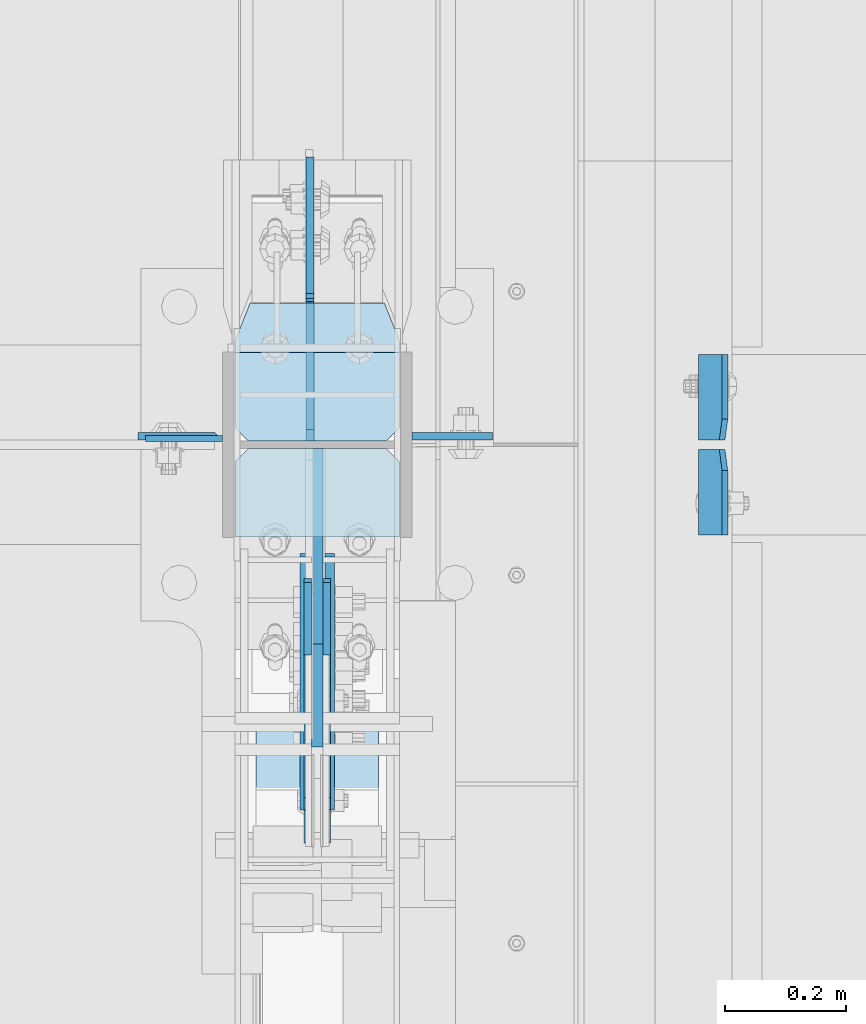
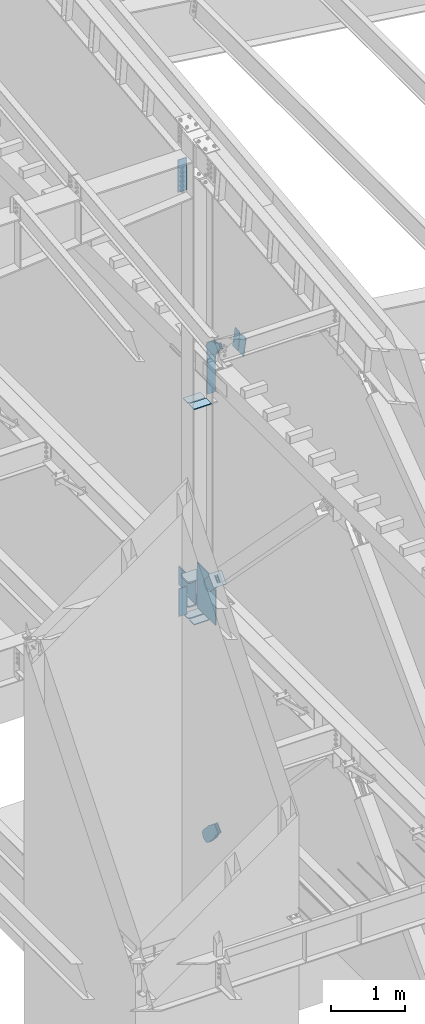
# One storey, part 1035 of 1179: 20 plates, 9 elements without a shape of their own.
"""IFC2X3 building model written with IfcOpenShell, lengths in millimetres."""

from ifc_helpers import new_model, si_unit, frame, origin_with_axes, place, context, subcontext, project, spatial, faceted_brep, material, type_object, element, aggregate, save


model = new_model("IFC2X3")

# Units and contexts
model_context = context("Model", 3, precision=1e-05, world=origin_with_axes())
body_context = subcontext(model_context, "Body", "Model", "MODEL_VIEW")
ifc_project = project(units=[si_unit("LENGTHUNIT", "METRE", prefix="MILLI"), si_unit("AREAUNIT", "SQUARE_METRE"), si_unit("VOLUMEUNIT", "CUBIC_METRE"), si_unit("MASSUNIT", "GRAM", prefix="KILO"), si_unit("TIMEUNIT", "SECOND"), si_unit("PLANEANGLEUNIT", "RADIAN"), si_unit("SOLIDANGLEUNIT", "STERADIAN"), si_unit("THERMODYNAMICTEMPERATUREUNIT", "DEGREE_CELSIUS"), si_unit("LUMINOUSINTENSITYUNIT", "LUMEN")], contexts=[model_context])

# Site, building, storey
site_placement = place(None, origin_with_axes())
site = spatial("IfcSite", under=ifc_project, at=site_placement, CompositionType="ELEMENT")
building_placement = place(site_placement, origin_with_axes())
building = spatial("IfcBuilding", under=site, at=building_placement, Name="Undefined", CompositionType="ELEMENT")
storey_placement = place(building_placement, origin_with_axes())
storey = spatial("IfcBuildingStorey", under=building, at=storey_placement, Name="Undefined", CompositionType="ELEMENT", Elevation=0.0)

# Assembly, plates
assembly_1_placement = place(storey_placement, origin_with_axes())
assembly_1 = element("IfcElementAssembly", 1, at=assembly_1_placement, inside=storey, Name="COLUMN", AssemblyPlace="NOTDEFINED", PredefinedType="RIGID_FRAME")
ifc_material_1 = material(Name="STEEL/A36")
plate_type_1 = type_object("IfcPlateType", PredefinedType="NOTDEFINED")
plate_1_placement = place(assembly_1_placement, frame((24150.6375, 19238.11875, 4051.3), z_axis=(-1.0, 0.0, 0.0), x_axis=(0.0, 0.0, -1.0)))
plate_1 = element("IfcPlate", 2, at=plate_1_placement, type_object=plate_type_1, material=ifc_material_1, Name="PLATE", context=body_context, shape_type="Brep", body=[
    faceted_brep([(0.0, -4.76249999999709, 0.0), (0.0, -4.76249999999709, 127.0), (0.0, 4.76249999999709, 127.0), (0.0, 4.76249999999709, 0.0), (457.200012207031, -4.76250000000073, 127.0), (457.200012207031, 4.76250000000073, 127.0), (457.200012207031, -4.76250000000073, 0.0), (457.200012207031, 4.76250000000073, 0.0)], [[[0, 1, 2, 3]], [[1, 4, 5, 2]], [[4, 6, 7, 5]], [[6, 0, 3, 7]], [[5, 7, 3, 2]], [[6, 4, 1, 0]]]),
])
plate_type_2 = type_object("IfcPlateType", PredefinedType="NOTDEFINED")
plate_2_placement = place(assembly_1_placement, frame((24010.9375000232, 19242.0874999987, 11089.4812512635), z_axis=(0.0, 0.0, -1.0), x_axis=(1.0, 0.0, 0.0)))
plate_2 = element("IfcPlate", 3, at=plate_2_placement, type_object=plate_type_2, material=ifc_material_1, Name="PLATE", context=body_context, shape_type="Brep", body=[
    faceted_brep([(127.000004873051, -6.34999999999854, 0.0), (139.699999999997, 6.35000000000036, 0.0), (139.700000000001, 6.35000000000036, 533.4), (127.0, -6.35000000000036, 533.4), (0.0, -6.34999999999854, 0.0), (0.0, -6.35000000000036, 533.4), (0.0, 6.35000000000036, 533.4), (0.0, 6.34999999999854, 0.0)], [[[0, 1, 2, 3]], [[4, 5, 6, 7]], [[6, 5, 3, 2]], [[4, 7, 1, 0]], [[2, 1, 7, 6]], [[5, 4, 0, 3]]]),
])

assembly_2_placement = place(storey_placement, origin_with_axes())
assembly_2 = element("IfcElementAssembly", 4, at=assembly_2_placement, inside=storey, Name="BEAM", AssemblyPlace="NOTDEFINED", PredefinedType="RIGID_FRAME")
plate_type_3 = type_object("IfcPlateType", PredefinedType="NOTDEFINED")
plate_3_placement = place(assembly_2_placement, frame((24982.9723149444, 19235.7375, 7924.64444967849), z_axis=(0.0, 1.0, 0.0), x_axis=(-0.133813222971046, 0.0, -0.991006569785539)))
plate_3 = element("IfcPlate", 5, at=plate_3_placement, type_object=plate_type_3, material=ifc_material_1, Name="PLATE", context=body_context, shape_type="Brep", body=[
    faceted_brep([(0.0, -4.76250000000073, 34.9249999999993), (0.0, -4.76250000001164, 141.287499999999), (-3.63797880709171e-12, 4.76249999998981, 141.287499999999), (0.0, 4.76250000000073, 34.9249999999993), (290.512500000297, -4.76249999966967, 141.287499999999), (290.512500000294, 4.76250000033906, 141.287499999999), (290.512500000297, -4.76249999966967, 0.0), (290.512500000294, 4.76250000033906, 0.0), (34.9249992370715, -4.76249999996799, 0.0), (34.9249992370678, 4.76250000003347, 0.0)], [[[0, 1, 2, 3]], [[1, 4, 5, 2]], [[4, 6, 7, 5]], [[6, 8, 9, 7]], [[8, 0, 3, 9]], [[5, 7, 9, 3, 2]], [[8, 6, 4, 1, 0]]]),
])
plate_4_placement = place(assembly_2_placement, frame((24982.9723149183, 19219.8625, 7924.6444497185), z_axis=(0.0, -1.0, 0.0), x_axis=(-0.133813222971046, 0.0, -0.991006569785539)))
plate_4 = element("IfcPlate", 6, at=plate_4_placement, type_object=plate_type_3, material=ifc_material_1, Name="PLATE", context=body_context, shape_type="Brep", body=[
    faceted_brep([(0.0, -4.76250000000073, 34.9249999999993), (0.0, -4.76250000001164, 141.287499999999), (-3.63797880709171e-12, 4.76249999998981, 141.287499999999), (0.0, 4.76250000000073, 34.9249999999993), (290.512500000297, -4.76249999966967, 141.287499999999), (290.512500000294, 4.76250000033906, 141.287499999999), (290.512500000297, -4.76249999966967, 0.0), (290.512500000294, 4.76250000033906, 0.0), (34.9249992370715, -4.76249999996799, 0.0), (34.9249992370678, 4.76250000003347, 0.0)], [[[0, 1, 2, 3]], [[1, 4, 5, 2]], [[4, 6, 7, 5]], [[6, 8, 9, 7]], [[8, 0, 3, 9]], [[5, 7, 9, 3, 2]], [[8, 6, 4, 1, 0]]]),
])
aggregate(assembly_2, [plate_3, plate_4])

# Assembly, plate
assembly_3_placement = place(storey_placement, origin_with_axes())
assembly_3 = element("IfcElementAssembly", 7, at=assembly_3_placement, inside=storey, AssemblyPlace="NOTDEFINED", PredefinedType="RIGID_FRAME")
plate_type_4 = type_object("IfcPlateType", PredefinedType="NOTDEFINED")
plate_5_placement = place(assembly_3_placement, frame((24291.925, 18622.7881405217, 8362.36594073939), z_axis=(0.0, -0.591857899923171, -0.806042322895352), x_axis=(0.0, 0.806042322895357, -0.591857899923163)))
plate_5 = element("IfcPlate", 8, at=plate_5_placement, type_object=plate_type_4, material=ifc_material_1, context=body_context, shape_type="Brep", body=[
    faceted_brep([(0.0, -6.34999999999854, 0.0), (-8.18545231595635e-11, -6.34999999999854, 91.5986124346418), (-8.18545231595635e-11, 6.34999999999854, 91.5986124346418), (0.0, 6.34999999999854, 0.0), (82.5500000001266, -6.34999999999854, 91.5986124347546), (82.5500000001266, 6.34999999999854, 91.5986124347546), (184.150000000493, -6.34999999999854, 136.286806217293), (184.150000000493, 6.34999999999854, 136.286806217293), (329.234985848627, -6.34999999999854, 136.286806217511), (329.234985848627, 6.34999999999854, 136.286806217511), (363.86305410257, -6.34999999999854, 129.398855183379), (363.86305410257, 6.34999999999854, 129.398855183379), (393.219312869078, -6.34999999999854, 109.783630186394), (393.219312869078, 6.34999999999854, 109.783630186394), (412.8345378661, -6.34999999999854, 80.4273714198789), (412.8345378661, 6.34999999999854, 80.4273714198789), (419.72248890029, -6.34999999999854, 45.7993092699908), (419.72248890029, 6.34999999999854, 45.7993092699908), (412.834537866132, -6.34999999999854, 11.171241015978), (412.834537866132, 6.34999999999854, 11.171241015978), (393.219312869132, -6.34999999999854, -18.1850177505985), (393.219312869132, 6.34999999999854, -18.1850177505985), (363.863054102636, -6.34999999999854, -37.8002427476786), (363.863054102636, 6.34999999999854, -37.8002427476786), (329.234988900062, -6.34999999999854, -44.6881937819198), (329.234988900062, 6.34999999999854, -44.6881937819198), (184.150000000598, -6.34999999999854, -44.6881937821345), (184.150000000598, 6.34999999999854, -44.6881937821345), (82.550000000203, -6.34999999999854, 1.2732925824821e-10), (82.550000000203, 6.34999999999854, 1.2732925824821e-10)], [[[0, 1, 2, 3]], [[1, 4, 5, 2]], [[4, 6, 7, 5]], [[6, 8, 9, 7]], [[8, 10, 11, 9]], [[10, 12, 13, 11]], [[12, 14, 15, 13]], [[14, 16, 17, 15]], [[16, 18, 19, 17]], [[18, 20, 21, 19]], [[20, 22, 23, 21]], [[22, 24, 25, 23]], [[24, 26, 27, 25]], [[26, 28, 29, 27]], [[28, 0, 3, 29]], [[5, 7, 9, 11, 13, 15, 17, 19, 21, 23, 25, 27, 29, 3, 2]], [[28, 26, 24, 22, 20, 18, 16, 14, 12, 10, 8, 6, 4, 1, 0]]]),
])
aggregate(assembly_3, [plate_5])

assembly_4_placement = place(storey_placement, origin_with_axes())
assembly_4 = element("IfcElementAssembly", 9, at=assembly_4_placement, inside=storey, AssemblyPlace="NOTDEFINED", PredefinedType="RIGID_FRAME")
plate_6_placement = place(assembly_4_placement, frame((24323.675, 18622.7881405217, 8362.36594073939), z_axis=(0.0, -0.591857899923171, -0.806042322895352), x_axis=(0.0, 0.806042322895357, -0.591857899923163)))
plate_6 = element("IfcPlate", 10, at=plate_6_placement, type_object=plate_type_4, material=ifc_material_1, context=body_context, shape_type="Brep", body=[
    faceted_brep([(0.0, -6.34999999999854, 0.0), (-8.18545231595635e-11, -6.34999999999854, 91.5986124346418), (-8.18545231595635e-11, 6.34999999999854, 91.5986124346418), (0.0, 6.34999999999854, 0.0), (82.5500000001266, -6.34999999999854, 91.5986124347546), (82.5500000001266, 6.34999999999854, 91.5986124347546), (184.150000000493, -6.34999999999854, 136.286806217293), (184.150000000493, 6.34999999999854, 136.286806217293), (329.234985848627, -6.34999999999854, 136.286806217511), (329.234985848627, 6.34999999999854, 136.286806217511), (363.86305410257, -6.34999999999854, 129.398855183379), (363.86305410257, 6.34999999999854, 129.398855183379), (393.219312869078, -6.34999999999854, 109.783630186394), (393.219312869078, 6.34999999999854, 109.783630186394), (412.8345378661, -6.34999999999854, 80.4273714198789), (412.8345378661, 6.34999999999854, 80.4273714198789), (419.72248890029, -6.34999999999854, 45.7993092699908), (419.72248890029, 6.34999999999854, 45.7993092699908), (412.834537866132, -6.34999999999854, 11.171241015978), (412.834537866132, 6.34999999999854, 11.171241015978), (393.219312869132, -6.34999999999854, -18.1850177505985), (393.219312869132, 6.34999999999854, -18.1850177505985), (363.863054102636, -6.34999999999854, -37.8002427476786), (363.863054102636, 6.34999999999854, -37.8002427476786), (329.234988900062, -6.34999999999854, -44.6881937819198), (329.234988900062, 6.34999999999854, -44.6881937819198), (184.150000000598, -6.34999999999854, -44.6881937821345), (184.150000000598, 6.34999999999854, -44.6881937821345), (82.550000000203, -6.34999999999854, 1.2732925824821e-10), (82.550000000203, 6.34999999999854, 1.2732925824821e-10)], [[[0, 1, 2, 3]], [[1, 4, 5, 2]], [[4, 6, 7, 5]], [[6, 8, 9, 7]], [[8, 10, 11, 9]], [[10, 12, 13, 11]], [[12, 14, 15, 13]], [[14, 16, 17, 15]], [[16, 18, 19, 17]], [[18, 20, 21, 19]], [[20, 22, 23, 21]], [[22, 24, 25, 23]], [[24, 26, 27, 25]], [[26, 28, 29, 27]], [[28, 0, 3, 29]], [[5, 7, 9, 11, 13, 15, 17, 19, 21, 23, 25, 27, 29, 3, 2]], [[28, 26, 24, 22, 20, 18, 16, 14, 12, 10, 8, 6, 4, 1, 0]]]),
])
aggregate(assembly_4, [plate_6])

assembly_5_placement = place(storey_placement, origin_with_axes())
assembly_5 = element("IfcElementAssembly", 11, at=assembly_5_placement, inside=storey, Name="Plate", AssemblyPlace="NOTDEFINED", PredefinedType="RIGID_FRAME")
plate_type_5 = type_object("IfcPlateType", PredefinedType="NOTDEFINED")
plate_7_placement = place(assembly_5_placement, frame((24206.2, 18613.4934226276, 4376.50104382377), z_axis=(0.0, 0.71564233903776, 0.698466923036849), x_axis=(1.0, 0.0, 0.0)))
plate_7 = element("IfcPlate", 12, at=plate_7_placement, type_object=plate_type_5, material=ifc_material_1, Name="Plate", context=body_context, shape_type="Brep", body=[
    faceted_brep([(0.0, -3.17500000000109, 0.0), (0.0, -3.17500000000291, 203.200000000368), (0.0, 3.17499999998836, 203.200000000361), (0.0, 3.17500000000109, 7.27595761418343e-12), (203.199999999997, -3.17500000000291, 203.200000000368), (203.199999999997, 3.17499999998836, 203.200000000361), (203.199999999997, -3.17499999999927, 3.63797880709171e-12), (203.199999999997, 3.17499999999382, -3.63797880709171e-12)], [[[0, 1, 2, 3]], [[1, 4, 5, 2]], [[4, 6, 7, 5]], [[6, 0, 3, 7]], [[5, 7, 3, 2]], [[6, 4, 1, 0]]]),
])
aggregate(assembly_5, [plate_7])

# Plate
ifc_material_2 = material(Name="STEEL/A572-GR.50")
plate_type_6 = type_object("IfcPlateType", PredefinedType="NOTDEFINED")
plate_8_placement = place(assembly_1_placement, frame((24444.325, 19462.75, 3694.1125), z_axis=(-1.0, 0.0, 0.0), x_axis=(0.0, -1.0, 0.0)))
plate_8 = element("IfcPlate", 13, at=plate_8_placement, type_object=plate_type_6, material=ifc_material_2, Name="PLATE", context=body_context, shape_type="Brep", body=[
    faceted_brep([(0.0, -11.1125000000002, 247.650000381473), (63.5, -11.1125000000002, 273.050000000003), (63.5, 11.1125000000002, 273.050000000003), (0.0, 11.1125000000002, 247.650000381473), (63.5, -11.1125000000002, 0.0), (0.0, -11.1125000000002, 25.3999996185303), (0.0, 11.1125000000002, 25.3999996185303), (63.5, 11.1125000000002, 0.0), (206.374999618529, -11.1125000000002, 0.0), (206.374999618529, 11.1125000000002, 0.0), (228.599999999999, -11.1125000000002, 22.2250003814697), (228.599999999999, 11.1125000000002, 22.2250003814697), (228.599999999999, -11.1125000000002, 250.824999618533), (228.599999999999, 11.1125000000002, 250.824999618533), (206.374999618529, -11.1125000000002, 273.050000000003), (206.374999618529, 11.1125000000002, 273.050000000003)], [[[0, 1, 2, 3]], [[4, 5, 6, 7]], [[8, 4, 7, 9]], [[10, 8, 9, 11]], [[12, 10, 11, 13]], [[14, 12, 13, 15]], [[4, 8, 10, 12, 14, 1, 0, 5]], [[5, 0, 3, 6]], [[2, 15, 13, 11, 9, 7, 6, 3]], [[1, 14, 15, 2]]]),
])

plate_9_placement = place(assembly_1_placement, frame((24444.325, 19462.75, 4090.9875), z_axis=(-1.0, 0.0, 0.0), x_axis=(0.0, -1.0, 0.0)))
plate_9 = element("IfcPlate", 14, at=plate_9_placement, type_object=plate_type_6, material=ifc_material_2, Name="PLATE", context=body_context, shape_type="Brep", body=[
    faceted_brep([(0.0, -11.1125000000002, 247.650000381473), (63.5, -11.1125000000002, 273.050000000003), (63.5, 11.1125000000002, 273.050000000003), (0.0, 11.1125000000002, 247.650000381473), (63.5, -11.1125000000002, 0.0), (0.0, -11.1125000000002, 25.3999996185303), (0.0, 11.1125000000002, 25.3999996185303), (63.5, 11.1125000000002, 0.0), (206.374999618529, -11.1125000000002, 0.0), (206.374999618529, 11.1125000000002, 0.0), (228.599999999999, -11.1125000000002, 22.2250003814697), (228.599999999999, 11.1125000000002, 22.2250003814697), (228.599999999999, -11.1125000000002, 250.824999618533), (228.599999999999, 11.1125000000002, 250.824999618533), (206.374999618529, -11.1125000000002, 273.050000000003), (206.374999618529, 11.1125000000002, 273.050000000003)], [[[0, 1, 2, 3]], [[4, 5, 6, 7]], [[8, 4, 7, 9]], [[10, 8, 9, 11]], [[12, 10, 11, 13]], [[14, 12, 13, 15]], [[4, 8, 10, 12, 14, 1, 0, 5]], [[5, 0, 3, 6]], [[2, 15, 13, 11, 9, 7, 6, 3]], [[1, 14, 15, 2]]]),
])

plate_type_7 = type_object("IfcPlateType", PredefinedType="NOTDEFINED")
plate_10_placement = place(assembly_1_placement, frame((24444.325, 19221.45, 7039.6831388093), z_axis=(-1.0, 0.0, 0.0), x_axis=(0.0, -1.0, 0.0)))
plate_10 = element("IfcPlate", 15, at=plate_10_placement, type_object=plate_type_7, material=ifc_material_1, Name="PLATE", context=body_context, shape_type="Brep", body=[
    faceted_brep([(0.0, -6.34999999999854, 22.2250003814697), (0.0, -6.35000000000036, 250.82499961853), (0.0, 6.35000000000036, 250.82499961853), (0.0, 6.34999999999854, 22.2250003814697), (22.2250003814697, -6.35000000000036, 273.05), (22.2250003814697, 6.35000000000036, 273.05), (146.050003051758, -6.35000000000036, 273.049987792969), (146.050003051758, 6.35000000000036, 273.049987792969), (146.050003051758, -6.35000000000036, 0.0), (146.050003051758, 6.35000000000036, 0.0), (22.2250003814697, -6.34999999999854, 0.0), (22.2250003814697, 6.34999999999854, 0.0)], [[[0, 1, 2, 3]], [[1, 4, 5, 2]], [[4, 6, 7, 5]], [[6, 8, 9, 7]], [[8, 10, 11, 9]], [[10, 0, 3, 11]], [[5, 7, 9, 11, 3, 2]], [[10, 8, 6, 4, 1, 0]]]),
])

plate_11_placement = place(assembly_1_placement, frame((24444.325, 19380.2, 7039.6831388093), z_axis=(-1.0, 0.0, 0.0), x_axis=(0.0, -1.0, 0.0)))
plate_11 = element("IfcPlate", 16, at=plate_11_placement, type_object=plate_type_7, material=ifc_material_1, Name="PLATE", context=body_context, shape_type="Brep", body=[
    faceted_brep([(0.0, -6.34999999999854, 0.0), (0.0, -6.34999999999991, 273.05), (0.0, 6.34999999999991, 273.05), (0.0, 6.34999999999854, 0.0), (123.824999618599, -6.34999999999991, 273.05), (123.824999618599, 6.34999999999991, 273.05), (146.050000000068, -6.34999999999991, 250.82499961853), (146.050000000068, 6.34999999999991, 250.82499961853), (146.050000000068, -6.34999999999991, 22.2250003814697), (146.050000000068, 6.34999999999991, 22.2250003814697), (123.824999618599, -6.34999999999991, 0.0), (123.824999618599, 6.34999999999991, 0.0)], [[[0, 1, 2, 3]], [[1, 4, 5, 2]], [[4, 6, 7, 5]], [[6, 8, 9, 7]], [[8, 10, 11, 9]], [[10, 0, 3, 11]], [[5, 7, 9, 11, 3, 2]], [[10, 8, 6, 4, 1, 0]]]),
])

plate_12_placement = place(assembly_1_placement, frame((24444.325, 19221.45, 3505.2), z_axis=(-1.0, 0.0, 0.0), x_axis=(0.0, -1.0, 0.0)))
plate_12 = element("IfcPlate", 17, at=plate_12_placement, type_object=plate_type_7, material=ifc_material_1, Name="PLATE", context=body_context, shape_type="Brep", body=[
    faceted_brep([(0.0, -6.34999999999854, 22.2250003814697), (0.0, -6.35000000000036, 250.82499961853), (0.0, 6.35000000000036, 250.82499961853), (0.0, 6.34999999999854, 22.2250003814697), (22.2250003814697, -6.35000000000036, 273.05), (22.2250003814697, 6.35000000000036, 273.05), (146.050003051758, -6.35000000000036, 273.049987792969), (146.050003051758, 6.35000000000036, 273.049987792969), (146.050003051758, -6.35000000000036, 0.0), (146.050003051758, 6.35000000000036, 0.0), (22.2250003814697, -6.34999999999854, 0.0), (22.2250003814697, 6.34999999999854, 0.0)], [[[0, 1, 2, 3]], [[1, 4, 5, 2]], [[4, 6, 7, 5]], [[6, 8, 9, 7]], [[8, 10, 11, 9]], [[10, 0, 3, 11]], [[5, 7, 9, 11, 3, 2]], [[10, 8, 6, 4, 1, 0]]]),
])

plate_13_placement = place(assembly_1_placement, frame((24444.325, 19380.2, 3505.2), z_axis=(-1.0, 0.0, 0.0), x_axis=(0.0, -1.0, 0.0)))
plate_13 = element("IfcPlate", 18, at=plate_13_placement, type_object=plate_type_7, material=ifc_material_1, Name="PLATE", context=body_context, shape_type="Brep", body=[
    faceted_brep([(0.0, -6.34999999999854, 0.0), (0.0, -6.34999999999991, 273.05), (0.0, 6.34999999999991, 273.05), (0.0, 6.34999999999854, 0.0), (123.824999618599, -6.34999999999991, 273.05), (123.824999618599, 6.34999999999991, 273.05), (146.050000000068, -6.34999999999991, 250.82499961853), (146.050000000068, 6.34999999999991, 250.82499961853), (146.050000000068, -6.34999999999991, 22.2250003814697), (146.050000000068, 6.34999999999991, 22.2250003814697), (123.824999618599, -6.34999999999991, 0.0), (123.824999618599, 6.34999999999991, 0.0)], [[[0, 1, 2, 3]], [[1, 4, 5, 2]], [[4, 6, 7, 5]], [[6, 8, 9, 7]], [[8, 10, 11, 9]], [[10, 0, 3, 11]], [[5, 7, 9, 11, 3, 2]], [[10, 8, 6, 4, 1, 0]]]),
])

plate_type_8 = type_object("IfcPlateType", PredefinedType="NOTDEFINED")
plate_14_placement = place(assembly_1_placement, frame((24464.9625, 19242.0875, 7936.73589790168), z_axis=(1.0, 0.0, 0.0), x_axis=(0.0, 0.0, -1.0)))
plate_14 = element("IfcPlate", 19, at=plate_14_placement, type_object=plate_type_8, material=ifc_material_1, Name="PLATE", context=body_context, shape_type="Brep", body=[
    faceted_brep([(0.0, -6.34999999999854, 0.0), (0.0, -6.34999999999854, 133.350000000002), (0.0, 6.34999999999854, 133.350000000002), (0.0, 6.34999999999854, 0.0), (850.900024414062, -6.34999999999854, 133.350006103516), (850.900024414062, 6.34999999999854, 133.350006103516), (850.900024414062, -6.34999999999854, 0.0), (850.900024414062, 6.34999999999854, 0.0)], [[[0, 1, 2, 3]], [[1, 4, 5, 2]], [[4, 6, 7, 5]], [[6, 0, 3, 7]], [[5, 7, 3, 2]], [[6, 4, 1, 0]]]),
])

# Assembly, plate
assembly_6_placement = place(storey_placement, origin_with_axes())
assembly_6 = element("IfcElementAssembly", 20, at=assembly_6_placement, inside=storey, AssemblyPlace="NOTDEFINED", PredefinedType="RIGID_FRAME")
plate_type_9 = type_object("IfcPlateType", PredefinedType="NOTDEFINED")
plate_15_placement = place(assembly_6_placement, frame((24291.925, 18724.1271949358, 4488.91617934531), z_axis=(0.0, -0.715642339037757, -0.698466923036852), x_axis=(0.0, 0.698466923036852, -0.715642339037758)))
plate_15 = element("IfcPlate", 21, at=plate_15_placement, type_object=plate_type_9, material=ifc_material_1, context=body_context, shape_type="Brep", body=[
    faceted_brep([(0.0, -6.34999999999854, 0.0), (-4.35647962149233e-10, -6.34999999999854, 112.184930806416), (-4.35647962149233e-10, 6.34999999999854, 112.184930806416), (0.0, 6.34999999999854, 0.0), (82.5499999996491, -6.34999999999854, 112.184930806461), (82.5499999996491, 6.34999999999854, 112.184930806461), (184.149999999618, -6.34999999999854, 149.75496540347), (184.149999999618, 6.34999999999854, 149.75496540347), (327.919242323534, -6.34999999999854, 149.754965403559), (327.919242323534, 6.34999999999854, 149.754965403559), (363.762328723451, -6.34999999999854, 142.625332233587), (363.762328723451, 6.34999999999854, 142.625332233587), (394.148630137406, -6.34999999999854, 122.321854743475), (394.148630137406, 6.34999999999854, 122.321854743475), (414.452107627645, -6.34999999999854, 91.9355533295929), (414.452107627645, 6.34999999999854, 91.9355533295929), (421.581740797776, -6.34999999999854, 56.0924638777396), (421.581740797776, 6.34999999999854, 56.0924638777396), (414.452107627878, -6.34999999999854, 20.2493774776722), (414.452107627878, 6.34999999999854, 20.2493774776722), (394.14863013775, -6.34999999999854, -10.1369239363994), (394.14863013775, 6.34999999999854, -10.1369239363994), (363.762328723789, -6.34999999999854, -30.4404014266784), (363.762328723789, 6.34999999999854, -30.4404014266784), (327.919240798041, -6.34999999999854, -37.570034596738), (327.919240798041, 6.34999999999854, -37.570034596738), (184.150000000338, -6.34999999999854, -37.5700345968289), (184.150000000338, 6.34999999999854, -37.5700345968289), (82.550000000203, -6.34999999999854, 1.2732925824821e-10), (82.550000000203, 6.34999999999854, 1.2732925824821e-10)], [[[0, 1, 2, 3]], [[1, 4, 5, 2]], [[4, 6, 7, 5]], [[6, 8, 9, 7]], [[8, 10, 11, 9]], [[10, 12, 13, 11]], [[12, 14, 15, 13]], [[14, 16, 17, 15]], [[16, 18, 19, 17]], [[18, 20, 21, 19]], [[20, 22, 23, 21]], [[22, 24, 25, 23]], [[24, 26, 27, 25]], [[26, 28, 29, 27]], [[28, 0, 3, 29]], [[5, 7, 9, 11, 13, 15, 17, 19, 21, 23, 25, 27, 29, 3, 2]], [[28, 26, 24, 22, 20, 18, 16, 14, 12, 10, 8, 6, 4, 1, 0]]]),
])
aggregate(assembly_6, [plate_15])

assembly_7_placement = place(storey_placement, origin_with_axes())
assembly_7 = element("IfcElementAssembly", 22, at=assembly_7_placement, inside=storey, AssemblyPlace="NOTDEFINED", PredefinedType="RIGID_FRAME")
plate_16_placement = place(assembly_7_placement, frame((24323.675, 18724.1271949358, 4488.91617934531), z_axis=(0.0, -0.715642339037757, -0.698466923036852), x_axis=(0.0, 0.698466923036852, -0.715642339037758)))
plate_16 = element("IfcPlate", 23, at=plate_16_placement, type_object=plate_type_9, material=ifc_material_1, context=body_context, shape_type="Brep", body=[
    faceted_brep([(0.0, -6.34999999999854, 0.0), (-4.35647962149233e-10, -6.34999999999854, 112.184930806416), (-4.35647962149233e-10, 6.34999999999854, 112.184930806416), (0.0, 6.34999999999854, 0.0), (82.5499999996491, -6.34999999999854, 112.184930806461), (82.5499999996491, 6.34999999999854, 112.184930806461), (184.149999999618, -6.34999999999854, 149.75496540347), (184.149999999618, 6.34999999999854, 149.75496540347), (327.919242323534, -6.34999999999854, 149.754965403559), (327.919242323534, 6.34999999999854, 149.754965403559), (363.762328723451, -6.34999999999854, 142.625332233587), (363.762328723451, 6.34999999999854, 142.625332233587), (394.148630137406, -6.34999999999854, 122.321854743475), (394.148630137406, 6.34999999999854, 122.321854743475), (414.452107627645, -6.34999999999854, 91.9355533295929), (414.452107627645, 6.34999999999854, 91.9355533295929), (421.581740797776, -6.34999999999854, 56.0924638777396), (421.581740797776, 6.34999999999854, 56.0924638777396), (414.452107627878, -6.34999999999854, 20.2493774776722), (414.452107627878, 6.34999999999854, 20.2493774776722), (394.14863013775, -6.34999999999854, -10.1369239363994), (394.14863013775, 6.34999999999854, -10.1369239363994), (363.762328723789, -6.34999999999854, -30.4404014266784), (363.762328723789, 6.34999999999854, -30.4404014266784), (327.919240798041, -6.34999999999854, -37.570034596738), (327.919240798041, 6.34999999999854, -37.570034596738), (184.150000000338, -6.34999999999854, -37.5700345968289), (184.150000000338, 6.34999999999854, -37.5700345968289), (82.550000000203, -6.34999999999854, 1.2732925824821e-10), (82.550000000203, 6.34999999999854, 1.2732925824821e-10)], [[[0, 1, 2, 3]], [[1, 4, 5, 2]], [[4, 6, 7, 5]], [[6, 8, 9, 7]], [[8, 10, 11, 9]], [[10, 12, 13, 11]], [[12, 14, 15, 13]], [[14, 16, 17, 15]], [[16, 18, 19, 17]], [[18, 20, 21, 19]], [[20, 22, 23, 21]], [[22, 24, 25, 23]], [[24, 26, 27, 25]], [[26, 28, 29, 27]], [[28, 0, 3, 29]], [[5, 7, 9, 11, 13, 15, 17, 19, 21, 23, 25, 27, 29, 3, 2]], [[28, 26, 24, 22, 20, 18, 16, 14, 12, 10, 8, 6, 4, 1, 0]]]),
])
aggregate(assembly_7, [plate_16])

# Plate
plate_type_10 = type_object("IfcPlateType", PredefinedType="NOTDEFINED")
plate_17_placement = place(assembly_1_placement, frame((24307.8, 19221.45, 3663.95), z_axis=(0.0, 0.0, 1.0), x_axis=(0.0, -1.0, 0.0)))
plate_17 = element("IfcPlate", 24, at=plate_17_placement, type_object=plate_type_10, material=ifc_material_2, Name="PLATE", context=body_context, shape_type="Brep", body=[
    faceted_brep([(0.0, -9.52499999999964, 0.0), (-3.63797880709171e-12, -9.52499999999998, 737.163128918689), (-3.63797880709171e-12, 9.52499999999998, 737.163128918689), (0.0, 9.52499999999964, 0.0), (323.636098339506, -9.52499999999998, 737.163128918689), (323.636098339506, 9.52499999999998, 737.163128918689), (494.048430322873, -9.52499999999998, 570.84069287054), (494.048430322873, 9.52499999999998, 570.84069287054), (494.048430322877, -9.52499999999998, 0.0), (494.048430322877, 9.52499999999998, 0.0)], [[[0, 1, 2, 3]], [[1, 4, 5, 2]], [[4, 6, 7, 5]], [[6, 8, 9, 7]], [[8, 0, 3, 9]], [[5, 7, 9, 3, 2]], [[8, 6, 4, 1, 0]]]),
])

# Assembly, plate
assembly_8_placement = place(storey_placement, origin_with_axes())
assembly_8 = element("IfcElementAssembly", 25, at=assembly_8_placement, inside=storey, AssemblyPlace="NOTDEFINED", PredefinedType="RIGID_FRAME")
plate_type_11 = type_object("IfcPlateType", PredefinedType="NOTDEFINED")
plate_18_placement = place(assembly_8_placement, frame((24287.1625, 18729.4707277224, 419.729946485768), z_axis=(0.0, -0.727605443744034, -0.685995858758672), x_axis=(0.0, 0.685995858758672, -0.727605443744034)))
plate_18 = element("IfcPlate", 26, at=plate_18_placement, type_object=plate_type_11, material=ifc_material_1, context=body_context, shape_type="Brep", body=[
    faceted_brep([(0.0, -7.9375, 0.0), (-8.00355337560177e-11, -7.9375, 146.904840309817), (-8.00355337560177e-11, 7.9375, 146.904840309817), (0.0, 7.9375, 0.0), (82.5499999998137, -7.9375, 146.90484031055), (82.5499999998137, 7.9375, 146.90484031055), (184.150000000214, -7.9375, 168.702420155054), (184.150000000214, 7.9375, 168.702420155054), (403.471138850085, -7.9375, 168.70242015493), (403.471138850085, 7.9375, 168.70242015493), (439.921735782846, -7.9375, 161.451945626626), (439.921735782846, 7.9375, 161.451945626626), (470.823059758064, -7.9375, 140.804341062974), (470.823059758064, 7.9375, 140.804341062974), (491.470664321725, -7.9375, 109.903017087783), (491.470664321725, 7.9375, 109.903017087783), (498.721138850011, -7.9375, 73.4524201549993), (498.721138850011, 7.9375, 73.4524201549993), (491.470664321694, -7.9375, 37.001823222241), (491.470664321694, 7.9375, 37.001823222241), (470.82305975797, -7.9375, 6.10049924700979), (470.82305975797, 7.9375, 6.10049924700979), (439.921735782676, -7.9375, -14.5471053166548), (439.921735782676, 7.9375, -14.5471053166548), (403.471138849898, -7.9375, -21.7975798449352), (403.471138849898, 7.9375, -21.7975798449352), (184.150000000169, -7.9375, -21.7975798448115), (184.150000000169, 7.9375, -21.7975798448115), (82.5500000000975, -7.9375, -6.91215973347425e-11), (82.5500000000975, 7.9375, -6.91215973347425e-11)], [[[0, 1, 2, 3]], [[1, 4, 5, 2]], [[4, 6, 7, 5]], [[6, 8, 9, 7]], [[8, 10, 11, 9]], [[10, 12, 13, 11]], [[12, 14, 15, 13]], [[14, 16, 17, 15]], [[16, 18, 19, 17]], [[18, 20, 21, 19]], [[20, 22, 23, 21]], [[22, 24, 25, 23]], [[24, 26, 27, 25]], [[26, 28, 29, 27]], [[28, 0, 3, 29]], [[5, 7, 9, 11, 13, 15, 17, 19, 21, 23, 25, 27, 29, 3, 2]], [[28, 26, 24, 22, 20, 18, 16, 14, 12, 10, 8, 6, 4, 1, 0]]]),
])
aggregate(assembly_8, [plate_18])

assembly_9_placement = place(storey_placement, origin_with_axes())
assembly_9 = element("IfcElementAssembly", 27, at=assembly_9_placement, inside=storey, AssemblyPlace="NOTDEFINED", PredefinedType="RIGID_FRAME")
plate_19_placement = place(assembly_9_placement, frame((24328.4375, 18729.4707277224, 419.729946485768), z_axis=(0.0, -0.727605443744034, -0.685995858758672), x_axis=(0.0, 0.685995858758672, -0.727605443744034)))
plate_19 = element("IfcPlate", 28, at=plate_19_placement, type_object=plate_type_11, material=ifc_material_1, context=body_context, shape_type="Brep", body=[
    faceted_brep([(0.0, -7.9375, 0.0), (-8.00355337560177e-11, -7.9375, 146.904840309817), (-8.00355337560177e-11, 7.9375, 146.904840309817), (0.0, 7.9375, 0.0), (82.5499999998137, -7.9375, 146.90484031055), (82.5499999998137, 7.9375, 146.90484031055), (184.150000000214, -7.9375, 168.702420155054), (184.150000000214, 7.9375, 168.702420155054), (403.471138850085, -7.9375, 168.70242015493), (403.471138850085, 7.9375, 168.70242015493), (439.921735782846, -7.9375, 161.451945626626), (439.921735782846, 7.9375, 161.451945626626), (470.823059758064, -7.9375, 140.804341062974), (470.823059758064, 7.9375, 140.804341062974), (491.470664321725, -7.9375, 109.903017087783), (491.470664321725, 7.9375, 109.903017087783), (498.721138850011, -7.9375, 73.4524201549993), (498.721138850011, 7.9375, 73.4524201549993), (491.470664321694, -7.9375, 37.001823222241), (491.470664321694, 7.9375, 37.001823222241), (470.82305975797, -7.9375, 6.10049924700979), (470.82305975797, 7.9375, 6.10049924700979), (439.921735782676, -7.9375, -14.5471053166548), (439.921735782676, 7.9375, -14.5471053166548), (403.471138849898, -7.9375, -21.7975798449352), (403.471138849898, 7.9375, -21.7975798449352), (184.150000000169, -7.9375, -21.7975798448115), (184.150000000169, 7.9375, -21.7975798448115), (82.5500000000975, -7.9375, -6.91215973347425e-11), (82.5500000000975, 7.9375, -6.91215973347425e-11)], [[[0, 1, 2, 3]], [[1, 4, 5, 2]], [[4, 6, 7, 5]], [[6, 8, 9, 7]], [[8, 10, 11, 9]], [[10, 12, 13, 11]], [[12, 14, 15, 13]], [[14, 16, 17, 15]], [[16, 18, 19, 17]], [[18, 20, 21, 19]], [[20, 22, 23, 21]], [[22, 24, 25, 23]], [[24, 26, 27, 25]], [[26, 28, 29, 27]], [[28, 0, 3, 29]], [[5, 7, 9, 11, 13, 15, 17, 19, 21, 23, 25, 27, 29, 3, 2]], [[28, 26, 24, 22, 20, 18, 16, 14, 12, 10, 8, 6, 4, 1, 0]]]),
])
aggregate(assembly_9, [plate_19])

# Plate
plate_type_12 = type_object("IfcPlateType", PredefinedType="NOTDEFINED")
plate_20_placement = place(assembly_1_placement, frame((24295.89375, 19234.1500000077, 3724.275), z_axis=(0.0, 0.707106781186542, 0.707106781186553), x_axis=(0.0, 0.707106781186553, -0.707106781186542)))
plate_20 = element("IfcPlate", 29, at=plate_20_placement, type_object=plate_type_12, material=ifc_material_2, Name="PLATE", context=body_context, shape_type="Brep", body=[
    faceted_brep([(0.0, -6.34999999999854, 0.0), (-237.976787208419, -6.34999999999854, 237.976787208414), (-237.976787208419, 6.34999999999854, 237.976787208414), (0.0, 6.34999999999854, 0.0), (-237.976787208489, -6.34999999999854, 264.917555571561), (-237.976787208489, 6.34999999999854, 264.917555571561), (-89.8025612115634, -6.34999999999854, 413.09178156849), (-89.8025612115634, 6.34999999999854, 413.09178156849), (-87.5574986365136, -6.35000000000002, 410.846713673389), (-87.5574986365136, 6.35000000000002, 410.846713673389), (-79.3171439752477, -6.34999999999854, 405.340689467515), (-79.3171439752477, 6.34999999999854, 405.340689467515), (-69.5969849391658, -6.34999999999854, 403.407229622333), (-69.5969849391658, 6.34999999999854, 403.407229622333), (-59.8768259030876, -6.34999999999854, 405.340689467494), (-59.8768259030876, 6.34999999999854, 405.340689467494), (-51.6364729667966, -6.34999999999854, 410.84671726843), (-51.6364729667966, 6.34999999999854, 410.84671726843), (101.027881360342, -6.34999999999854, 563.511071595573), (101.027881360342, 6.34999999999854, 563.511071595573), (316.554028266077, -6.34999999999854, 347.984924689843), (316.554028266077, 6.34999999999854, 347.984924689843), (163.889673938938, -6.34999999999854, 195.320570362701), (163.889673938938, 6.34999999999854, 195.320570362701), (158.383646138001, -6.34999999999854, 187.080217426408), (158.383646138001, 6.34999999999854, 187.080217426408), (156.450186292839, -6.34999999999854, 177.360058390334), (156.450186292839, 6.34999999999854, 177.360058390334), (158.383646138027, -6.34999999999854, 167.639899354248), (158.383646138027, 6.34999999999854, 167.639899354248), (163.889673938986, -6.34999999999854, 159.399546417944), (163.889673938986, 6.34999999999854, 159.399546417944), (175.114994360907, -6.34999999999854, 148.174225997692), (175.114994360907, 6.34999999999854, 148.174225997692), (26.9407683631471, -6.34999999999854, -6.91215973347425e-11), (26.9407683631471, 6.34999999999854, -6.91215973347425e-11)], [[[0, 1, 2, 3]], [[1, 4, 5, 2]], [[4, 6, 7, 5]], [[6, 8, 9, 7]], [[8, 10, 11, 9]], [[10, 12, 13, 11]], [[12, 14, 15, 13]], [[14, 16, 17, 15]], [[16, 18, 19, 17]], [[18, 20, 21, 19]], [[20, 22, 23, 21]], [[22, 24, 25, 23]], [[24, 26, 27, 25]], [[26, 28, 29, 27]], [[28, 30, 31, 29]], [[30, 32, 33, 31]], [[32, 34, 35, 33]], [[34, 0, 3, 35]], [[5, 7, 9, 11, 13, 15, 17, 19, 21, 23, 25, 27, 29, 31, 33, 35, 3, 2]], [[34, 32, 30, 28, 26, 24, 22, 20, 18, 16, 14, 12, 10, 8, 6, 4, 1, 0]]]),
])

aggregate(assembly_1, [plate_17, plate_2, plate_10, plate_11, plate_14, plate_8, plate_9, plate_20, plate_12, plate_13, plate_1])

save(model, "model.ifc")
